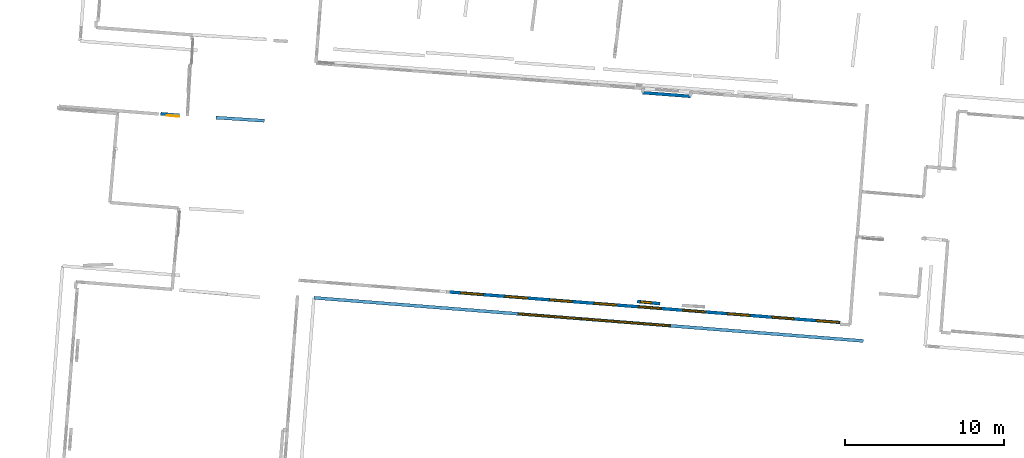
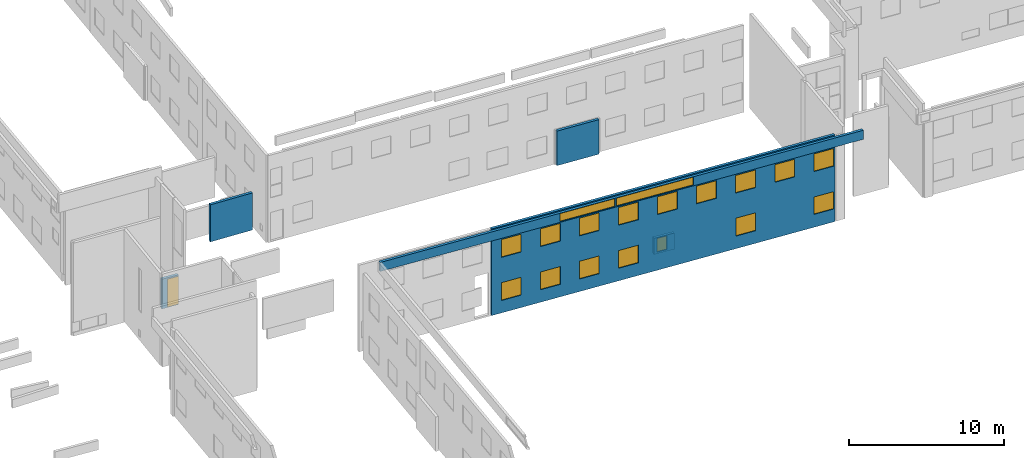
# One storey, part 8 of 27: 18 windows, 6 walls, 1 door, 19 openings.
"""IFC2X3 building model written with IfcOpenShell, lengths in metres."""

from ifc_helpers import new_model, entity, si_unit, converted_unit, derived_unit, direction, frame, frame_2d, origin, origin_2d_with_axis, place, context, subcontext, project, spatial, polyline, rectangle, outline, extrude, source, transform, mapped, material, layer, layer_set, layer_usage, type_object, type_shapes, element, fill, save


model = new_model("IFC2X3")

# Units and contexts
model_context = context("Model", 3, precision=1e-05, world=origin(), true_north=direction((0.0, 1.0)))
body_context = subcontext(model_context, "Body", "Model", "MODEL_VIEW")
ifc_project = project(units=[si_unit("LENGTHUNIT", "METRE"), si_unit("AREAUNIT", "SQUARE_METRE"), si_unit("VOLUMEUNIT", "CUBIC_METRE"), converted_unit("PLANEANGLEUNIT", "DEGREE", entity("IfcRatioMeasure", 0.0174532925199433), si_unit("PLANEANGLEUNIT", "RADIAN"), dimensions=[0, 0, 0, 0, 0, 0, 0]), si_unit("MASSUNIT", "GRAM", prefix="KILO"), derived_unit("MASSDENSITYUNIT", [(si_unit("MASSUNIT", "GRAM", prefix="KILO"), 1), (si_unit("LENGTHUNIT", "METRE"), -3)]), derived_unit("MOMENTOFINERTIAUNIT", [(si_unit("LENGTHUNIT", "METRE"), 4)]), si_unit("TIMEUNIT", "SECOND"), si_unit("FREQUENCYUNIT", "HERTZ"), si_unit("THERMODYNAMICTEMPERATUREUNIT", "DEGREE_CELSIUS"), derived_unit("THERMALTRANSMITTANCEUNIT", [(si_unit("MASSUNIT", "GRAM", prefix="KILO"), 1), (si_unit("THERMODYNAMICTEMPERATUREUNIT", "KELVIN"), -1), (si_unit("TIMEUNIT", "SECOND"), -3)]), derived_unit("VOLUMETRICFLOWRATEUNIT", [(si_unit("LENGTHUNIT", "METRE"), 3), (si_unit("TIMEUNIT", "SECOND"), -1)]), si_unit("ELECTRICCURRENTUNIT", "AMPERE"), si_unit("ELECTRICVOLTAGEUNIT", "VOLT"), si_unit("POWERUNIT", "WATT"), si_unit("FORCEUNIT", "NEWTON", prefix="KILO"), si_unit("ILLUMINANCEUNIT", "LUX"), si_unit("LUMINOUSFLUXUNIT", "LUMEN"), si_unit("LUMINOUSINTENSITYUNIT", "CANDELA"), derived_unit("USERDEFINED", [(si_unit("MASSUNIT", "GRAM", prefix="KILO"), -1), (si_unit("LENGTHUNIT", "METRE"), -2), (si_unit("TIMEUNIT", "SECOND"), 3), (si_unit("LUMINOUSFLUXUNIT", "LUMEN"), 1)]), derived_unit("LINEARVELOCITYUNIT", [(si_unit("LENGTHUNIT", "METRE"), 1), (si_unit("TIMEUNIT", "SECOND"), -1)]), si_unit("PRESSUREUNIT", "PASCAL"), derived_unit("USERDEFINED", [(si_unit("LENGTHUNIT", "METRE"), -2), (si_unit("MASSUNIT", "GRAM", prefix="KILO"), 1), (si_unit("TIMEUNIT", "SECOND"), -2)]), derived_unit("LINEARFORCEUNIT", [(si_unit("MASSUNIT", "GRAM", prefix="KILO"), 1), (si_unit("LENGTHUNIT", "METRE"), 1), (si_unit("TIMEUNIT", "SECOND"), -2), (si_unit("LENGTHUNIT", "METRE"), -1)]), derived_unit("PLANARFORCEUNIT", [(si_unit("MASSUNIT", "GRAM", prefix="KILO"), 1), (si_unit("LENGTHUNIT", "METRE"), 1), (si_unit("TIMEUNIT", "SECOND"), -2), (si_unit("LENGTHUNIT", "METRE"), -2)])], contexts=[model_context])

# Site, building, storey
placement_1 = place(None, origin())
site = spatial("IfcSite", under=ifc_project, at=placement_1, CompositionType="ELEMENT")
building = spatial("IfcBuilding", under=site, at=placement_1, CompositionType="ELEMENT")
storey_placement = place(placement_1, frame((0.0, 0.0, -61.043098449707)))
storey = spatial("IfcBuildingStorey", under=building, at=storey_placement, Name="level_-61.043098", CompositionType="ELEMENT", Elevation=-61.043098449707)

# Wall, opening, door
ifc_material_1 = material(Name="Default wall")
ifc_layer = layer(ifc_material_1, 0.2)
ifc_layer_set = layer_set([ifc_layer], Name="wall_thickness_0.2000")
ifc_layer_usage = layer_usage(ifc_layer_set, "AXIS2", "POSITIVE", -0.1)
wall_type = type_object("IfcWallType", Name="wall_thickness_0.2000", PredefinedType="STANDARD", material=ifc_layer_set)
placement_2 = place(placement_1, frame((0.0, 0.0, -60.9578857421875)))
wall_1_placement = place(placement_2, frame((-79.1080014723341, -2.90586131258313, 0.0), z_axis=(0.0, 0.0, 1.0), x_axis=(-0.996453111728566, 0.0841498432943191, 0.0)))
wall_1 = element("IfcWallStandardCase", 1, at=wall_1_placement, inside=storey, type_object=wall_type, material=ifc_layer_usage, Name="Wall:70", ObjectType="Wall", context=body_context, shape_type="SweptSolid", body=[
    extrude(outline(polyline([(1.17999708540066, -0.1), (1.17999708540066, 0.1), (0.0, 0.1), (0.0, -0.1), (1.17999708540066, -0.1)])), origin(), (0.0, 0.0, 1.0), 2.34577560424805),
])
opening_1_placement = place(wall_1_placement, frame((0.00499973385200103, -0.1, 0.0413627624511719)))
opening_1 = element("IfcOpeningElement", 2, at=opening_1_placement, cuts=wall_1, Name="Opening : 790 x 2195 : 0", ObjectType="Opening", context=body_context, shape_type="SweptSolid", body=[
    extrude(rectangle(XDim=0.79, YDim=2.195, at=frame_2d((1.0975, 0.395), x_axis=(0.0, 1.0))), frame((0.0, 0.0, 0.0), z_axis=(0.0, 1.0, 0.0), x_axis=(0.0, 0.0, 1.0)), (0.0, 0.0, 1.0), 0.2),
])
ifc_material_2 = material(Name="Door Panel")
door_style = type_object("IfcDoorStyle", Name="Door : 790 x 2195mm", ConstructionType="NOTDEFINED", OperationType="SINGLE_SWING_RIGHT", ParameterTakesPrecedence=False, Sizeable=False, material=ifc_material_2)
shared_shape_1 = source(origin(), body_context, "Body", "SweptSolid", [
    extrude(rectangle(XDim=0.05, YDim=0.79, at=origin_2d_with_axis()), frame((0.395, 0.175, 0.0), z_axis=(0.0, 0.0, 1.0), x_axis=(0.0, 1.0, 0.0)), (0.0, 0.0, 1.0), 2.195),
])
type_shapes(door_style, [shared_shape_1])
door_placement = place(opening_1_placement, origin())
door = element("IfcDoor", 3, at=door_placement, inside=storey, type_object=door_style, Name="Door : 790 x 2195mm : 0", ObjectType="Door : 790 x 2195mm", OverallHeight=2.195, OverallWidth=0.79, context=body_context, shape_type="MappedRepresentation", body=[
    mapped(shared_shape_1, transform((0.0, 0.0, 0.0), scale=1.0)),
])
fill(opening_1, door)

# Wall, openings, windows
placement_3 = place(placement_1, frame((0.0, 0.0, -54.3638687133789)))
wall_2_placement = place(placement_3, frame((-70.6673771995799, -14.3603034624491, 0.0), z_axis=(0.0, 0.0, 1.0), x_axis=(0.996928819141734, -0.0783130229570317, 0.0)))
wall_2 = element("IfcWallStandardCase", 4, at=wall_2_placement, inside=storey, type_object=wall_type, material=ifc_layer_usage, Name="Wall:130", ObjectType="Wall", context=body_context, shape_type="SweptSolid", body=[
    extrude(outline(polyline([(34.5901651482046, -0.1), (34.5901651482046, 0.1), (0.0, 0.1), (0.0, -0.1), (34.5901651482046, -0.1)])), origin(), (0.0, 0.0, 1.0), 0.715465545654297),
])
opening_2_placement = place(wall_2_placement, frame((12.8749791124871, -0.1, 0.0550003051757812)))
opening_2 = element("IfcOpeningElement", 5, at=opening_2_placement, cuts=wall_2, Name="Opening : 3935 x 635 : 2", ObjectType="Opening", context=body_context, shape_type="SweptSolid", body=[
    extrude(rectangle(XDim=3.935, YDim=0.635, at=frame_2d((0.3175, 1.9675), x_axis=(0.0, 1.0))), frame((0.0, 0.0, 0.0), z_axis=(0.0, 1.0, 0.0), x_axis=(0.0, 0.0, 1.0)), (0.0, 0.0, 1.0), 0.2),
])
opening_3_placement = place(wall_2_placement, frame((16.904976056931, -0.1, 0.0550003051757812)))
opening_3 = element("IfcOpeningElement", 6, at=opening_3_placement, cuts=wall_2, Name="Opening : 5520 x 635 : 3", ObjectType="Opening", context=body_context, shape_type="SweptSolid", body=[
    extrude(rectangle(XDim=5.52, YDim=0.635, at=frame_2d((0.3175, 2.76), x_axis=(0.0, 1.0))), frame((0.0, 0.0, 0.0), z_axis=(0.0, 1.0, 0.0), x_axis=(0.0, 0.0, 1.0)), (0.0, 0.0, 1.0), 0.2),
])
ifc_material_3 = material(Name="Window Default")
window_style_1 = type_object("IfcWindowStyle", Name="Window : 3935 x 635mm", ConstructionType="NOTDEFINED", OperationType="NOTDEFINED", ParameterTakesPrecedence=False, Sizeable=False, material=ifc_material_3)
shared_shape_2 = source(origin(), body_context, "Body", "SweptSolid", [
    extrude(rectangle(XDim=0.1, YDim=3.935, at=origin_2d_with_axis()), frame((1.9675, 0.1, 0.0), z_axis=(0.0, 0.0, 1.0), x_axis=(0.0, 1.0, 0.0)), (0.0, 0.0, 1.0), 0.635),
])
type_shapes(window_style_1, [shared_shape_2])
window_1_placement = place(opening_2_placement, origin())
window_1 = element("IfcWindow", 7, at=window_1_placement, inside=storey, type_object=window_style_1, Name="Window : 3935 x 635mm : 1", ObjectType="Window : 3935 x 635mm", OverallHeight=0.635, OverallWidth=3.935, context=body_context, shape_type="MappedRepresentation", body=[
    mapped(shared_shape_2, transform((0.0, 0.0, 0.0), scale=1.0)),
])
fill(opening_2, window_1)
window_style_2 = type_object("IfcWindowStyle", Name="Window : 5520 x 635mm", ConstructionType="NOTDEFINED", OperationType="NOTDEFINED", ParameterTakesPrecedence=False, Sizeable=False, material=ifc_material_3)
shared_shape_3 = source(origin(), body_context, "Body", "SweptSolid", [
    extrude(rectangle(XDim=0.1, YDim=5.52, at=origin_2d_with_axis()), frame((2.76, 0.1, 0.0), z_axis=(0.0, 0.0, 1.0), x_axis=(0.0, 1.0, 0.0)), (0.0, 0.0, 1.0), 0.635),
])
type_shapes(window_style_2, [shared_shape_3])
window_2_placement = place(opening_3_placement, origin())
window_2 = element("IfcWindow", 8, at=window_2_placement, inside=storey, type_object=window_style_2, Name="Window : 5520 x 635mm : 2", ObjectType="Window : 5520 x 635mm", OverallHeight=0.635, OverallWidth=5.52, context=body_context, shape_type="MappedRepresentation", body=[
    mapped(shared_shape_3, transform((0.0, 0.0, 0.0), scale=1.0)),
])
fill(opening_3, window_2)

# Wall, opening, window
placement_4 = place(placement_1, frame((0.0, 0.0, -59.9867630004883)))
wall_3_placement = place(placement_4, frame((-48.9351778119383, -14.7304373557948, 0.0), z_axis=(0.0, 0.0, 1.0), x_axis=(-0.995453977569209, 0.0952437847927132, 0.0)))
wall_3 = element("IfcWallStandardCase", 9, at=wall_3_placement, inside=storey, type_object=wall_type, material=ifc_layer_usage, Name="Wall:683", ObjectType="Wall", context=body_context, shape_type="SweptSolid", body=[
    extrude(outline(polyline([(1.44642533553543, -0.1), (1.44642533553543, 0.1), (0.0, 0.1), (0.0, -0.1), (1.44642533553543, -0.1)])), origin(), (0.0, 0.0, 1.0), 1.27852630615234),
])
opening_4_placement = place(wall_3_placement, frame((0.530001115100097, -0.1, 0.135353088378906)))
opening_4 = element("IfcOpeningElement", 10, at=opening_4_placement, cuts=wall_3, Name="Opening : 700 x 1075 : 71", ObjectType="Opening", context=body_context, shape_type="SweptSolid", body=[
    extrude(rectangle(XDim=0.7, YDim=1.075, at=frame_2d((0.5375, 0.35), x_axis=(0.0, 1.0))), frame((0.0, 0.0, 0.0), z_axis=(0.0, 1.0, 0.0), x_axis=(0.0, 0.0, 1.0)), (0.0, 0.0, 1.0), 0.2),
])
window_style_3 = type_object("IfcWindowStyle", Name="Window : 700 x 1075mm", ConstructionType="NOTDEFINED", OperationType="NOTDEFINED", ParameterTakesPrecedence=False, Sizeable=False, material=ifc_material_3)
shared_shape_4 = source(origin(), body_context, "Body", "SweptSolid", [
    extrude(rectangle(XDim=0.1, YDim=0.7, at=origin_2d_with_axis()), frame((0.35, 0.1, 0.0), z_axis=(0.0, 0.0, 1.0), x_axis=(0.0, 1.0, 0.0)), (0.0, 0.0, 1.0), 1.075),
])
type_shapes(window_style_3, [shared_shape_4])
window_3_placement = place(opening_4_placement, origin())
window_3 = element("IfcWindow", 11, at=window_3_placement, inside=storey, type_object=window_style_3, Name="Window : 700 x 1075mm : 63", ObjectType="Window : 700 x 1075mm", OverallHeight=1.075, OverallWidth=0.7, context=body_context, shape_type="MappedRepresentation", body=[
    mapped(shared_shape_4, transform((0.0, 0.0, 0.0), scale=1.0)),
])
fill(opening_4, window_3)

# Wall
placement_5 = place(placement_1, frame((0.0, 0.0, -56.7336082458496)))
wall_4_placement = place(placement_5, frame((-76.8143200675651, -3.05249813617034, 0.0), z_axis=(0.0, 0.0, 1.0), x_axis=(0.997951370139178, -0.0639770493015857, 0.0)))
element("IfcWallStandardCase", 12, at=wall_4_placement, inside=storey, type_object=wall_type, material=ifc_layer_usage, Name="Wall:875", ObjectType="Wall", context=body_context, shape_type="SweptSolid", body=[
    extrude(outline(polyline([(3.04000317086267, -0.1), (3.04000317086267, 0.1), (0.0, 0.1), (0.0, -0.1), (3.04000317086267, -0.1)])), origin(), (0.0, 0.0, 1.0), 2.92447662353516),
])

# Wall, openings, windows
wall_5_placement = place(storey_placement, frame((-62.1512952859073, -13.9972502857822, 0.0), z_axis=(0.0, 0.0, 1.0), x_axis=(0.996973839246706, -0.0777377891226906, 0.0)))
wall_5 = element("IfcWallStandardCase", 13, at=wall_5_placement, inside=storey, type_object=wall_type, material=ifc_layer_usage, Name="Wall:1116", ObjectType="Wall", context=body_context, shape_type="SweptSolid", body=[
    extrude(outline(polyline([(24.5921619924426, -0.1), (24.5921619924426, 0.1), (0.0, 0.1), (0.0, -0.1), (24.5921619924426, -0.1)])), origin(), (0.0, 0.0, 1.0), 6.83392333984375),
])
opening_5_placement = place(wall_5_placement, frame((17.4834726500269, -0.1, 4.39071273803711)))
opening_5 = element("IfcOpeningElement", 14, at=opening_5_placement, cuts=wall_5, Name="Opening : 1425 x 1390 : 144", ObjectType="Opening", context=body_context, shape_type="SweptSolid", body=[
    extrude(rectangle(XDim=1.425, YDim=1.39, at=frame_2d((0.695, 0.7125), x_axis=(0.0, 1.0))), frame((0.0, 0.0, 0.0), z_axis=(0.0, 1.0, 0.0), x_axis=(0.0, 0.0, 1.0)), (0.0, 0.0, 1.0), 0.2),
])
opening_6_placement = place(wall_5_placement, frame((20.278471714595, -0.1, 4.39071273803711)))
opening_6 = element("IfcOpeningElement", 15, at=opening_6_placement, cuts=wall_5, Name="Opening : 1425 x 1390 : 145", ObjectType="Opening", context=body_context, shape_type="SweptSolid", body=[
    extrude(rectangle(XDim=1.425, YDim=1.39, at=frame_2d((0.695, 0.7125), x_axis=(0.0, 1.0))), frame((0.0, 0.0, 0.0), z_axis=(0.0, 1.0, 0.0), x_axis=(0.0, 0.0, 1.0)), (0.0, 0.0, 1.0), 0.2),
])
opening_7_placement = place(wall_5_placement, frame((23.0784717483342, -0.1, 4.39571380615234)))
opening_7 = element("IfcOpeningElement", 16, at=opening_7_placement, cuts=wall_5, Name="Opening : 1415 x 1390 : 146", ObjectType="Opening", context=body_context, shape_type="SweptSolid", body=[
    extrude(rectangle(XDim=1.415, YDim=1.39, at=frame_2d((0.695, 0.7075), x_axis=(0.0, 1.0))), frame((0.0, 0.0, 0.0), z_axis=(0.0, 1.0, 0.0), x_axis=(0.0, 0.0, 1.0)), (0.0, 0.0, 1.0), 0.2),
])
opening_8_placement = place(wall_5_placement, frame((17.4884735450615, -0.1, 0.990715026855469)))
opening_8 = element("IfcOpeningElement", 17, at=opening_8_placement, cuts=wall_5, Name="Opening : 1425 x 1415 : 147", ObjectType="Opening", context=body_context, shape_type="SweptSolid", body=[
    extrude(rectangle(XDim=1.425, YDim=1.415, at=frame_2d((0.7075, 0.7125), x_axis=(0.0, 1.0))), frame((0.0, 0.0, 0.0), z_axis=(0.0, 1.0, 0.0), x_axis=(0.0, 0.0, 1.0)), (0.0, 0.0, 1.0), 0.2),
])
opening_9_placement = place(wall_5_placement, frame((23.0884698093865, -0.1, 1.01571273803711)))
opening_9 = element("IfcOpeningElement", 18, at=opening_9_placement, cuts=wall_5, Name="Opening : 1410 x 1370 : 148", ObjectType="Opening", context=body_context, shape_type="SweptSolid", body=[
    extrude(rectangle(XDim=1.41, YDim=1.37, at=frame_2d((0.685, 0.705), x_axis=(0.0, 1.0))), frame((0.0, 0.0, 0.0), z_axis=(0.0, 1.0, 0.0), x_axis=(0.0, 0.0, 1.0)), (0.0, 0.0, 1.0), 0.2),
])
opening_10_placement = place(wall_5_placement, frame((0.70500290126768, -0.1, 4.38047027587891)))
opening_10 = element("IfcOpeningElement", 19, at=opening_10_placement, cuts=wall_5, Name="Opening : 1415 x 1405 : 149", ObjectType="Opening", context=body_context, shape_type="SweptSolid", body=[
    extrude(rectangle(XDim=1.415, YDim=1.405, at=frame_2d((0.7025, 0.7075), x_axis=(0.0, 1.0))), frame((0.0, 0.0, 0.0), z_axis=(0.0, 1.0, 0.0), x_axis=(0.0, 0.0, 1.0)), (0.0, 0.0, 1.0), 0.2),
])
opening_11_placement = place(wall_5_placement, frame((3.49500099666469, -0.1, 4.39046859741211)))
opening_11 = element("IfcOpeningElement", 20, at=opening_11_placement, cuts=wall_5, Name="Opening : 1425 x 1400 : 150", ObjectType="Opening", context=body_context, shape_type="SweptSolid", body=[
    extrude(rectangle(XDim=1.425, YDim=1.4, at=frame_2d((0.7, 0.7125), x_axis=(0.0, 1.0))), frame((0.0, 0.0, 0.0), z_axis=(0.0, 1.0, 0.0), x_axis=(0.0, 0.0, 1.0)), (0.0, 0.0, 1.0), 0.2),
])
opening_12_placement = place(wall_5_placement, frame((6.29500110454041, -0.1, 4.39046859741211)))
opening_12 = element("IfcOpeningElement", 21, at=opening_12_placement, cuts=wall_5, Name="Opening : 1415 x 1395 : 151", ObjectType="Opening", context=body_context, shape_type="SweptSolid", body=[
    extrude(rectangle(XDim=1.415, YDim=1.395, at=frame_2d((0.6975, 0.7075), x_axis=(0.0, 1.0))), frame((0.0, 0.0, 0.0), z_axis=(0.0, 1.0, 0.0), x_axis=(0.0, 0.0, 1.0)), (0.0, 0.0, 1.0), 0.2),
])
opening_13_placement = place(wall_5_placement, frame((9.10000203331416, -0.1, 4.39046859741211)))
opening_13 = element("IfcOpeningElement", 22, at=opening_13_placement, cuts=wall_5, Name="Opening : 1410 x 1395 : 152", ObjectType="Opening", context=body_context, shape_type="SweptSolid", body=[
    extrude(rectangle(XDim=1.41, YDim=1.395, at=frame_2d((0.6975, 0.705), x_axis=(0.0, 1.0))), frame((0.0, 0.0, 0.0), z_axis=(0.0, 1.0, 0.0), x_axis=(0.0, 0.0, 1.0)), (0.0, 0.0, 1.0), 0.2),
])
opening_14_placement = place(wall_5_placement, frame((11.8950011720188, -0.1, 4.39046859741211)))
opening_14 = element("IfcOpeningElement", 23, at=opening_14_placement, cuts=wall_5, Name="Opening : 1420 x 1395 : 153", ObjectType="Opening", context=body_context, shape_type="SweptSolid", body=[
    extrude(rectangle(XDim=1.42, YDim=1.395, at=frame_2d((0.6975, 0.71), x_axis=(0.0, 1.0))), frame((0.0, 0.0, 0.0), z_axis=(0.0, 1.0, 0.0), x_axis=(0.0, 0.0, 1.0)), (0.0, 0.0, 1.0), 0.2),
])
opening_15_placement = place(wall_5_placement, frame((14.6800021755346, -0.1, 4.39046859741211)))
opening_15 = element("IfcOpeningElement", 24, at=opening_15_placement, cuts=wall_5, Name="Opening : 1430 x 1395 : 154", ObjectType="Opening", context=body_context, shape_type="SweptSolid", body=[
    extrude(rectangle(XDim=1.43, YDim=1.395, at=frame_2d((0.6975, 0.715), x_axis=(0.0, 1.0))), frame((0.0, 0.0, 0.0), z_axis=(0.0, 1.0, 0.0), x_axis=(0.0, 0.0, 1.0)), (0.0, 0.0, 1.0), 0.2),
])
opening_16_placement = place(wall_5_placement, frame((0.700001932096591, -0.1, 0.98046875)))
opening_16 = element("IfcOpeningElement", 25, at=opening_16_placement, cuts=wall_5, Name="Opening : 1415 x 1405 : 155", ObjectType="Opening", context=body_context, shape_type="SweptSolid", body=[
    extrude(rectangle(XDim=1.415, YDim=1.405, at=frame_2d((0.7025, 0.7075), x_axis=(0.0, 1.0))), frame((0.0, 0.0, 0.0), z_axis=(0.0, 1.0, 0.0), x_axis=(0.0, 0.0, 1.0)), (0.0, 0.0, 1.0), 0.2),
])
opening_17_placement = place(wall_5_placement, frame((3.49500099666469, -0.1, 0.985469818115234)))
opening_17 = element("IfcOpeningElement", 26, at=opening_17_placement, cuts=wall_5, Name="Opening : 1425 x 1400 : 156", ObjectType="Opening", context=body_context, shape_type="SweptSolid", body=[
    extrude(rectangle(XDim=1.425, YDim=1.4, at=frame_2d((0.7, 0.7125), x_axis=(0.0, 1.0))), frame((0.0, 0.0, 0.0), z_axis=(0.0, 1.0, 0.0), x_axis=(0.0, 0.0, 1.0)), (0.0, 0.0, 1.0), 0.2),
])
opening_18_placement = place(wall_5_placement, frame((6.29500110454041, -0.1, 0.985469818115234)))
opening_18 = element("IfcOpeningElement", 27, at=opening_18_placement, cuts=wall_5, Name="Opening : 1415 x 1400 : 157", ObjectType="Opening", context=body_context, shape_type="SweptSolid", body=[
    extrude(rectangle(XDim=1.415, YDim=1.4, at=frame_2d((0.7, 0.7075), x_axis=(0.0, 1.0))), frame((0.0, 0.0, 0.0), z_axis=(0.0, 1.0, 0.0), x_axis=(0.0, 0.0, 1.0)), (0.0, 0.0, 1.0), 0.2),
])
opening_19_placement = place(wall_5_placement, frame((9.0950011382796, -0.1, 0.990470886230469)))
opening_19 = element("IfcOpeningElement", 28, at=opening_19_placement, cuts=wall_5, Name="Opening : 1410 x 1395 : 158", ObjectType="Opening", context=body_context, shape_type="SweptSolid", body=[
    extrude(rectangle(XDim=1.41, YDim=1.395, at=frame_2d((0.6975, 0.705), x_axis=(0.0, 1.0))), frame((0.0, 0.0, 0.0), z_axis=(0.0, 1.0, 0.0), x_axis=(0.0, 0.0, 1.0)), (0.0, 0.0, 1.0), 0.2),
])
window_style_4 = type_object("IfcWindowStyle", Name="Window : 1425 x 1400mm", ConstructionType="NOTDEFINED", OperationType="NOTDEFINED", ParameterTakesPrecedence=False, Sizeable=False, material=ifc_material_3)
shared_shape_5 = source(origin(), body_context, "Body", "SweptSolid", [
    extrude(rectangle(XDim=0.1, YDim=1.425, at=origin_2d_with_axis()), frame((0.7125, 0.1, 0.0), z_axis=(0.0, 0.0, 1.0), x_axis=(0.0, 1.0, 0.0)), (0.0, 0.0, 1.0), 1.4),
])
type_shapes(window_style_4, [shared_shape_5])
window_4_placement = place(opening_11_placement, origin())
window_4 = element("IfcWindow", 29, at=window_4_placement, inside=storey, type_object=window_style_4, Name="Window : 1425 x 1400mm : 136", ObjectType="Window : 1425 x 1400mm", OverallHeight=1.4, OverallWidth=1.425, context=body_context, shape_type="MappedRepresentation", body=[
    mapped(shared_shape_5, transform((0.0, 0.0, 0.0), scale=1.0)),
])
fill(opening_11, window_4)
window_5_placement = place(opening_17_placement, origin())
window_5 = element("IfcWindow", 30, at=window_5_placement, inside=storey, type_object=window_style_4, Name="Window : 1425 x 1400mm : 142", ObjectType="Window : 1425 x 1400mm", OverallHeight=1.4, OverallWidth=1.425, context=body_context, shape_type="MappedRepresentation", body=[
    mapped(shared_shape_5, transform((0.0, 0.0, 0.0), scale=1.0)),
])
fill(opening_17, window_5)
window_style_5 = type_object("IfcWindowStyle", Name="Window : 1415 x 1405mm", ConstructionType="NOTDEFINED", OperationType="NOTDEFINED", ParameterTakesPrecedence=False, Sizeable=False, material=ifc_material_3)
shared_shape_6 = source(origin(), body_context, "Body", "SweptSolid", [
    extrude(rectangle(XDim=0.1, YDim=1.415, at=origin_2d_with_axis()), frame((0.7075, 0.1, 0.0), z_axis=(0.0, 0.0, 1.0), x_axis=(0.0, 1.0, 0.0)), (0.0, 0.0, 1.0), 1.405),
])
type_shapes(window_style_5, [shared_shape_6])
window_6_placement = place(opening_10_placement, origin())
window_6 = element("IfcWindow", 31, at=window_6_placement, inside=storey, type_object=window_style_5, Name="Window : 1415 x 1405mm : 135", ObjectType="Window : 1415 x 1405mm", OverallHeight=1.405, OverallWidth=1.415, context=body_context, shape_type="MappedRepresentation", body=[
    mapped(shared_shape_6, transform((0.0, 0.0, 0.0), scale=1.0)),
])
fill(opening_10, window_6)
window_7_placement = place(opening_16_placement, origin())
window_7 = element("IfcWindow", 32, at=window_7_placement, inside=storey, type_object=window_style_5, Name="Window : 1415 x 1405mm : 141", ObjectType="Window : 1415 x 1405mm", OverallHeight=1.405, OverallWidth=1.415, context=body_context, shape_type="MappedRepresentation", body=[
    mapped(shared_shape_6, transform((0.0, 0.0, 0.0), scale=1.0)),
])
fill(opening_16, window_7)
window_style_6 = type_object("IfcWindowStyle", Name="Window : 1420 x 1395mm", ConstructionType="NOTDEFINED", OperationType="NOTDEFINED", ParameterTakesPrecedence=False, Sizeable=False, material=ifc_material_3)
shared_shape_7 = source(origin(), body_context, "Body", "SweptSolid", [
    extrude(rectangle(XDim=0.1, YDim=1.42, at=origin_2d_with_axis()), frame((0.71, 0.1, 0.0), z_axis=(0.0, 0.0, 1.0), x_axis=(0.0, 1.0, 0.0)), (0.0, 0.0, 1.0), 1.395),
])
type_shapes(window_style_6, [shared_shape_7])
window_8_placement = place(opening_14_placement, origin())
window_8 = element("IfcWindow", 33, at=window_8_placement, inside=storey, type_object=window_style_6, Name="Window : 1420 x 1395mm : 139", ObjectType="Window : 1420 x 1395mm", OverallHeight=1.395, OverallWidth=1.42, context=body_context, shape_type="MappedRepresentation", body=[
    mapped(shared_shape_7, transform((0.0, 0.0, 0.0), scale=1.0)),
])
fill(opening_14, window_8)
window_style_7 = type_object("IfcWindowStyle", Name="Window : 1410 x 1395mm", ConstructionType="NOTDEFINED", OperationType="NOTDEFINED", ParameterTakesPrecedence=False, Sizeable=False, material=ifc_material_3)
shared_shape_8 = source(origin(), body_context, "Body", "SweptSolid", [
    extrude(rectangle(XDim=0.1, YDim=1.41, at=origin_2d_with_axis()), frame((0.705, 0.1, 0.0), z_axis=(0.0, 0.0, 1.0), x_axis=(0.0, 1.0, 0.0)), (0.0, 0.0, 1.0), 1.395),
])
type_shapes(window_style_7, [shared_shape_8])
window_9_placement = place(opening_13_placement, origin())
window_9 = element("IfcWindow", 34, at=window_9_placement, inside=storey, type_object=window_style_7, Name="Window : 1410 x 1395mm : 138", ObjectType="Window : 1410 x 1395mm", OverallHeight=1.395, OverallWidth=1.41, context=body_context, shape_type="MappedRepresentation", body=[
    mapped(shared_shape_8, transform((0.0, 0.0, 0.0), scale=1.0)),
])
fill(opening_13, window_9)
window_10_placement = place(opening_19_placement, origin())
window_10 = element("IfcWindow", 35, at=window_10_placement, inside=storey, type_object=window_style_7, Name="Window : 1410 x 1395mm : 144", ObjectType="Window : 1410 x 1395mm", OverallHeight=1.395, OverallWidth=1.41, context=body_context, shape_type="MappedRepresentation", body=[
    mapped(shared_shape_8, transform((0.0, 0.0, 0.0), scale=1.0)),
])
fill(opening_19, window_10)
window_style_8 = type_object("IfcWindowStyle", Name="Window : 1415 x 1400mm", ConstructionType="NOTDEFINED", OperationType="NOTDEFINED", ParameterTakesPrecedence=False, Sizeable=False, material=ifc_material_3)
shared_shape_9 = source(origin(), body_context, "Body", "SweptSolid", [
    extrude(rectangle(XDim=0.1, YDim=1.415, at=origin_2d_with_axis()), frame((0.7075, 0.1, 0.0), z_axis=(0.0, 0.0, 1.0), x_axis=(0.0, 1.0, 0.0)), (0.0, 0.0, 1.0), 1.4),
])
type_shapes(window_style_8, [shared_shape_9])
window_11_placement = place(opening_18_placement, origin())
window_11 = element("IfcWindow", 36, at=window_11_placement, inside=storey, type_object=window_style_8, Name="Window : 1415 x 1400mm : 143", ObjectType="Window : 1415 x 1400mm", OverallHeight=1.4, OverallWidth=1.415, context=body_context, shape_type="MappedRepresentation", body=[
    mapped(shared_shape_9, transform((0.0, 0.0, 0.0), scale=1.0)),
])
fill(opening_18, window_11)
window_style_9 = type_object("IfcWindowStyle", Name="Window : 1425 x 1390mm", ConstructionType="NOTDEFINED", OperationType="NOTDEFINED", ParameterTakesPrecedence=False, Sizeable=False, material=ifc_material_3)
shared_shape_10 = source(origin(), body_context, "Body", "SweptSolid", [
    extrude(rectangle(XDim=0.1, YDim=1.425, at=origin_2d_with_axis()), frame((0.7125, 0.1, 0.0), z_axis=(0.0, 0.0, 1.0), x_axis=(0.0, 1.0, 0.0)), (0.0, 0.0, 1.0), 1.39),
])
type_shapes(window_style_9, [shared_shape_10])
window_12_placement = place(opening_5_placement, origin())
window_12 = element("IfcWindow", 37, at=window_12_placement, inside=storey, type_object=window_style_9, Name="Window : 1425 x 1390mm : 130", ObjectType="Window : 1425 x 1390mm", OverallHeight=1.39, OverallWidth=1.425, context=body_context, shape_type="MappedRepresentation", body=[
    mapped(shared_shape_10, transform((0.0, 0.0, 0.0), scale=1.0)),
])
fill(opening_5, window_12)
window_13_placement = place(opening_6_placement, origin())
window_13 = element("IfcWindow", 38, at=window_13_placement, inside=storey, type_object=window_style_9, Name="Window : 1425 x 1390mm : 131", ObjectType="Window : 1425 x 1390mm", OverallHeight=1.39, OverallWidth=1.425, context=body_context, shape_type="MappedRepresentation", body=[
    mapped(shared_shape_10, transform((0.0, 0.0, 0.0), scale=1.0)),
])
fill(opening_6, window_13)
window_style_10 = type_object("IfcWindowStyle", Name="Window : 1415 x 1395mm", ConstructionType="NOTDEFINED", OperationType="NOTDEFINED", ParameterTakesPrecedence=False, Sizeable=False, material=ifc_material_3)
shared_shape_11 = source(origin(), body_context, "Body", "SweptSolid", [
    extrude(rectangle(XDim=0.1, YDim=1.415, at=origin_2d_with_axis()), frame((0.7075, 0.1, 0.0), z_axis=(0.0, 0.0, 1.0), x_axis=(0.0, 1.0, 0.0)), (0.0, 0.0, 1.0), 1.395),
])
type_shapes(window_style_10, [shared_shape_11])
window_14_placement = place(opening_12_placement, origin())
window_14 = element("IfcWindow", 39, at=window_14_placement, inside=storey, type_object=window_style_10, Name="Window : 1415 x 1395mm : 137", ObjectType="Window : 1415 x 1395mm", OverallHeight=1.395, OverallWidth=1.415, context=body_context, shape_type="MappedRepresentation", body=[
    mapped(shared_shape_11, transform((0.0, 0.0, 0.0), scale=1.0)),
])
fill(opening_12, window_14)
window_style_11 = type_object("IfcWindowStyle", Name="Window : 1410 x 1370mm", ConstructionType="NOTDEFINED", OperationType="NOTDEFINED", ParameterTakesPrecedence=False, Sizeable=False, material=ifc_material_3)
shared_shape_12 = source(origin(), body_context, "Body", "SweptSolid", [
    extrude(rectangle(XDim=0.1, YDim=1.41, at=origin_2d_with_axis()), frame((0.705, 0.1, 0.0), z_axis=(0.0, 0.0, 1.0), x_axis=(0.0, 1.0, 0.0)), (0.0, 0.0, 1.0), 1.37),
])
type_shapes(window_style_11, [shared_shape_12])
window_15_placement = place(opening_9_placement, origin())
window_15 = element("IfcWindow", 40, at=window_15_placement, inside=storey, type_object=window_style_11, Name="Window : 1410 x 1370mm : 134", ObjectType="Window : 1410 x 1370mm", OverallHeight=1.37, OverallWidth=1.41, context=body_context, shape_type="MappedRepresentation", body=[
    mapped(shared_shape_12, transform((0.0, 0.0, 0.0), scale=1.0)),
])
fill(opening_9, window_15)
window_style_12 = type_object("IfcWindowStyle", Name="Window : 1415 x 1390mm", ConstructionType="NOTDEFINED", OperationType="NOTDEFINED", ParameterTakesPrecedence=False, Sizeable=False, material=ifc_material_3)
shared_shape_13 = source(origin(), body_context, "Body", "SweptSolid", [
    extrude(rectangle(XDim=0.1, YDim=1.415, at=origin_2d_with_axis()), frame((0.7075, 0.1, 0.0), z_axis=(0.0, 0.0, 1.0), x_axis=(0.0, 1.0, 0.0)), (0.0, 0.0, 1.0), 1.39),
])
type_shapes(window_style_12, [shared_shape_13])
window_16_placement = place(opening_7_placement, origin())
window_16 = element("IfcWindow", 41, at=window_16_placement, inside=storey, type_object=window_style_12, Name="Window : 1415 x 1390mm : 132", ObjectType="Window : 1415 x 1390mm", OverallHeight=1.39, OverallWidth=1.415, context=body_context, shape_type="MappedRepresentation", body=[
    mapped(shared_shape_13, transform((0.0, 0.0, 0.0), scale=1.0)),
])
fill(opening_7, window_16)
window_style_13 = type_object("IfcWindowStyle", Name="Window : 1425 x 1415mm", ConstructionType="NOTDEFINED", OperationType="NOTDEFINED", ParameterTakesPrecedence=False, Sizeable=False, material=ifc_material_3)
shared_shape_14 = source(origin(), body_context, "Body", "SweptSolid", [
    extrude(rectangle(XDim=0.1, YDim=1.425, at=origin_2d_with_axis()), frame((0.7125, 0.1, 0.0), z_axis=(0.0, 0.0, 1.0), x_axis=(0.0, 1.0, 0.0)), (0.0, 0.0, 1.0), 1.415),
])
type_shapes(window_style_13, [shared_shape_14])
window_17_placement = place(opening_8_placement, origin())
window_17 = element("IfcWindow", 42, at=window_17_placement, inside=storey, type_object=window_style_13, Name="Window : 1425 x 1415mm : 133", ObjectType="Window : 1425 x 1415mm", OverallHeight=1.415, OverallWidth=1.425, context=body_context, shape_type="MappedRepresentation", body=[
    mapped(shared_shape_14, transform((0.0, 0.0, 0.0), scale=1.0)),
])
fill(opening_8, window_17)
window_style_14 = type_object("IfcWindowStyle", Name="Window : 1430 x 1395mm", ConstructionType="NOTDEFINED", OperationType="NOTDEFINED", ParameterTakesPrecedence=False, Sizeable=False, material=ifc_material_3)
shared_shape_15 = source(origin(), body_context, "Body", "SweptSolid", [
    extrude(rectangle(XDim=0.1, YDim=1.43, at=origin_2d_with_axis()), frame((0.715, 0.1, 0.0), z_axis=(0.0, 0.0, 1.0), x_axis=(0.0, 1.0, 0.0)), (0.0, 0.0, 1.0), 1.395),
])
type_shapes(window_style_14, [shared_shape_15])
window_18_placement = place(opening_15_placement, origin())
window_18 = element("IfcWindow", 43, at=window_18_placement, inside=storey, type_object=window_style_14, Name="Window : 1430 x 1395mm : 140", ObjectType="Window : 1430 x 1395mm", OverallHeight=1.395, OverallWidth=1.43, context=body_context, shape_type="MappedRepresentation", body=[
    mapped(shared_shape_15, transform((0.0, 0.0, 0.0), scale=1.0)),
])
fill(opening_15, window_18)

# Wall
wall_6_placement = place(storey_placement, frame((-47.0272797322072, -1.71549088734614, 0.0), z_axis=(0.0, 0.0, 1.0), x_axis=(-0.997067190874747, 0.0765311497440093, 0.0)))
element("IfcWallStandardCase", 44, at=wall_6_placement, inside=storey, type_object=wall_type, material=ifc_layer_usage, Name="Wall:1735", ObjectType="Wall", context=body_context, shape_type="SweptSolid", body=[
    extrude(outline(polyline([(3.02118967420814, -0.1), (3.02118967420814, 0.1), (0.0, 0.1), (0.0, -0.1), (3.02118967420814, -0.1)])), origin(), (0.0, 0.0, 1.0), 2.72571182250977),
])

save(model, "model.ifc")
